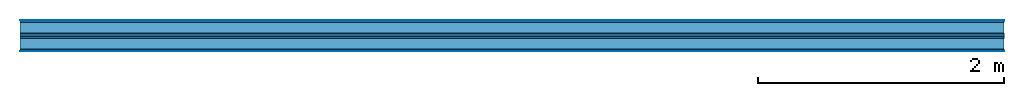
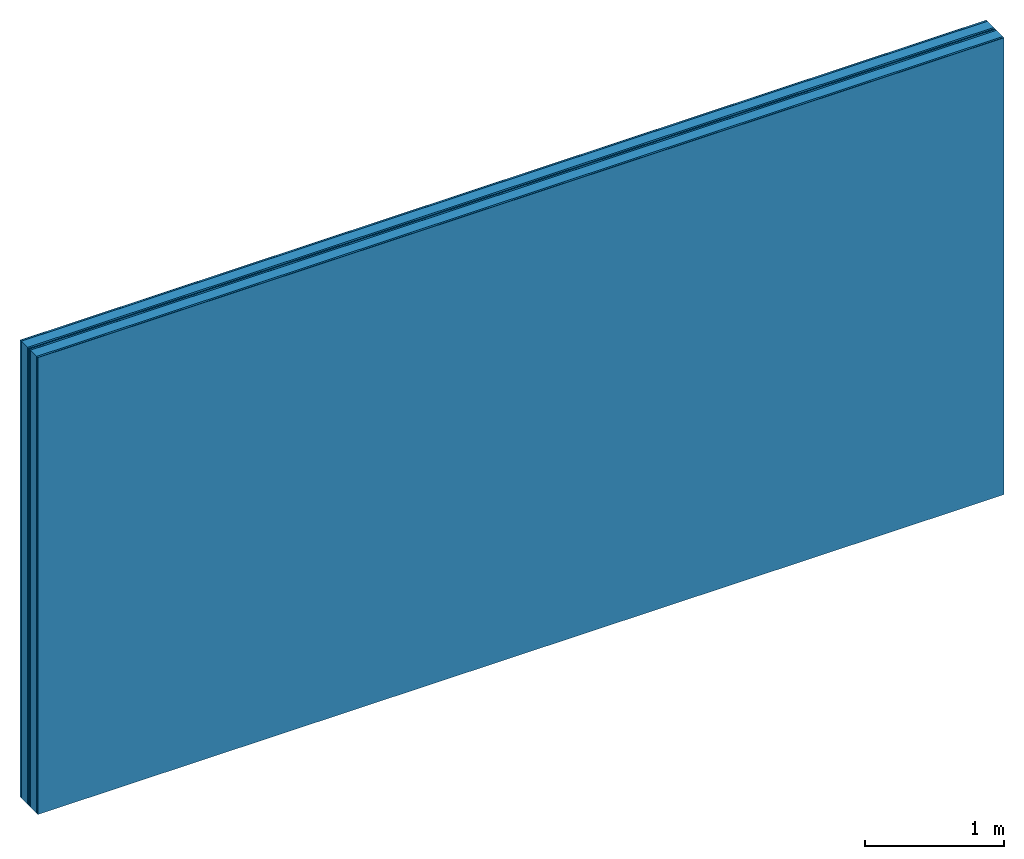
# One storey: 7 plates, 2 members, 1 element without a shape of its own.
"""IFC4 building model written with IfcOpenShell, lengths in metres."""

from ifc_helpers import new_model, si_unit, derived_unit, direction, frame, frame_2d, origin, origin_with_axes, place, context, project, spatial, rectangle, extrude, material, layer, layer_set, type_object, element, aggregate, save


model = new_model("IFC4")

# Units and contexts
plan_context = context("Plan", 3, precision=1e-05, world=origin(), true_north=direction((0.0, 1.0)))
model_context = context("Model", 3, precision=1e-05, world=origin(), true_north=direction((0.0, 1.0)))
ifc_project = project(units=[si_unit("LENGTHUNIT", "METRE"), derived_unit("SOUNDPRESSUREUNIT", [(si_unit("PRESSUREUNIT", "PASCAL", prefix="MICRO"), 0)]), si_unit("ENERGYUNIT", "JOULE", prefix="MEGA"), si_unit("MASSUNIT", "GRAM", prefix="KILO"), derived_unit("THERMALTRANSMITTANCEUNIT", [(si_unit("POWERUNIT", "WATT"), 1), (si_unit("AREAUNIT", "SQUARE_METRE"), -1), (si_unit("THERMODYNAMICTEMPERATUREUNIT", "KELVIN"), -1)]), derived_unit("AREADENSITYUNIT", [(si_unit("MASSUNIT", "GRAM", prefix="KILO"), 1), (si_unit("AREAUNIT", "SQUARE_METRE"), -1)]), derived_unit("USERDEFINED", [(si_unit("ENERGYUNIT", "JOULE", prefix="MEGA"), 1), (si_unit("AREAUNIT", "SQUARE_METRE"), -1)])], contexts=[plan_context, model_context])

# Site, building, storey
site = spatial("IfcSite", under=ifc_project)
building_placement = place(None, origin())
building = spatial("IfcBuilding", under=site, at=building_placement)
storey_placement = place(building_placement, origin())
storey = spatial("IfcBuildingStorey", under=building, at=storey_placement)

# Wall, members, plates
ifc_material_1 = material(Category="04.001")
ifc_layer_1 = layer(ifc_material_1, 0.003, Name="Surface")
ifc_material_2 = material(Name="DFH2IR Knauf Diamant hard- plasterboard", Category="03.007")
ifc_layer_2 = layer(ifc_material_2, 0.015, Name="room side 1st layer")
ifc_material_3 = material(Name="of the art")
ifc_layer_3 = layer(ifc_material_3, 0.0, Name="Bond")
ifc_layer_4 = layer(None, 0.09, Name="Support")
ifc_layer_5 = layer(ifc_material_3, 0.0, Name="Bond")
ifc_layer_6 = layer(ifc_material_2, 0.015, Name="outside 1st layer")
ifc_material_4 = material(Name="Air")
ifc_layer_7 = layer(ifc_material_4, 0.01, Name="Air gap")
ifc_layer_8 = layer(ifc_material_2, 0.015, Name="outside 1st layer")
ifc_layer_9 = layer(ifc_material_3, 0.0, Name="Bond")
ifc_layer_10 = layer(None, 0.09, Name="Support")
ifc_layer_11 = layer(ifc_material_3, 0.0, Name="Bond")
ifc_layer_12 = layer(ifc_material_2, 0.015, Name="room side 1st layer")
ifc_layer_13 = layer(ifc_material_1, 0.003, Name="Surface")
ifc_layer_set = layer_set([ifc_layer_1, ifc_layer_2, ifc_layer_3, ifc_layer_4, ifc_layer_5, ifc_layer_6, ifc_layer_7, ifc_layer_8, ifc_layer_9, ifc_layer_10, ifc_layer_11, ifc_layer_12, ifc_layer_13])
wall_type = type_object("IfcWallType", Name="B0298", PredefinedType="NOTDEFINED", material=ifc_layer_set)
wall_placement = place(None, frame((0.0, 0.0, 0.0), z_axis=(0.0, -1.0, 0.0), x_axis=(1.0, 0.0, 0.0)))
wall = element("IfcWall", 1, at=wall_placement, inside=storey, type_object=wall_type, material=ifc_layer_set, Name="Wall #1")
ifc_material_5 = material(Name="Solid timber panel")
member_1_placement = place(wall_placement, origin())
member_1 = element("IfcMember", 2, at=member_1_placement, material=ifc_material_5, Name="Support", context=plan_context, shape_type="SweptSolid", body=[
    extrude(rectangle(XDim=1.0, YDim=0.09, at=frame_2d((0.5, 0.045), x_axis=(1.0, 0.0))), frame((0.0, 4.0, 0.018), z_axis=(0.0, -1.0, 0.0), x_axis=(1.0, 0.0, 0.0)), (0.0, 0.0, 1.0), 4.0),
    extrude(rectangle(XDim=1.0, YDim=0.09, at=frame_2d((0.5, 0.045), x_axis=(1.0, 0.0))), frame((1.0, 4.0, 0.018), z_axis=(0.0, -1.0, 0.0), x_axis=(1.0, 0.0, 0.0)), (0.0, 0.0, 1.0), 4.0),
    extrude(rectangle(XDim=1.0, YDim=0.09, at=frame_2d((0.5, 0.045), x_axis=(1.0, 0.0))), frame((2.0, 4.0, 0.018), z_axis=(0.0, -1.0, 0.0), x_axis=(1.0, 0.0, 0.0)), (0.0, 0.0, 1.0), 4.0),
    extrude(rectangle(XDim=1.0, YDim=0.09, at=frame_2d((0.5, 0.045), x_axis=(1.0, 0.0))), frame((3.0, 4.0, 0.018), z_axis=(0.0, -1.0, 0.0), x_axis=(1.0, 0.0, 0.0)), (0.0, 0.0, 1.0), 4.0),
    extrude(rectangle(XDim=1.0, YDim=0.09, at=frame_2d((0.5, 0.045), x_axis=(1.0, 0.0))), frame((4.0, 4.0, 0.018), z_axis=(0.0, -1.0, 0.0), x_axis=(1.0, 0.0, 0.0)), (0.0, 0.0, 1.0), 4.0),
    extrude(rectangle(XDim=1.0, YDim=0.09, at=frame_2d((0.5, 0.045), x_axis=(1.0, 0.0))), frame((5.0, 4.0, 0.018), z_axis=(0.0, -1.0, 0.0), x_axis=(1.0, 0.0, 0.0)), (0.0, 0.0, 1.0), 4.0),
    extrude(rectangle(XDim=1.0, YDim=0.09, at=frame_2d((0.5, 0.045), x_axis=(1.0, 0.0))), frame((6.0, 4.0, 0.018), z_axis=(0.0, -1.0, 0.0), x_axis=(1.0, 0.0, 0.0)), (0.0, 0.0, 1.0), 4.0),
    extrude(rectangle(XDim=1.0, YDim=0.09, at=frame_2d((0.5, 0.045), x_axis=(1.0, 0.0))), frame((7.0, 4.0, 0.018), z_axis=(0.0, -1.0, 0.0), x_axis=(1.0, 0.0, 0.0)), (0.0, 0.0, 1.0), 4.0),
])
member_2_placement = place(wall_placement, origin())
member_2 = element("IfcMember", 3, at=member_2_placement, material=ifc_material_5, Name="Support", context=plan_context, shape_type="SweptSolid", body=[
    extrude(rectangle(XDim=1.0, YDim=0.09, at=frame_2d((0.5, 0.045), x_axis=(1.0, 0.0))), frame((0.0, 4.0, 0.148), z_axis=(0.0, -1.0, 0.0), x_axis=(1.0, 0.0, 0.0)), (0.0, 0.0, 1.0), 4.0),
    extrude(rectangle(XDim=1.0, YDim=0.09, at=frame_2d((0.5, 0.045), x_axis=(1.0, 0.0))), frame((1.0, 4.0, 0.148), z_axis=(0.0, -1.0, 0.0), x_axis=(1.0, 0.0, 0.0)), (0.0, 0.0, 1.0), 4.0),
    extrude(rectangle(XDim=1.0, YDim=0.09, at=frame_2d((0.5, 0.045), x_axis=(1.0, 0.0))), frame((2.0, 4.0, 0.148), z_axis=(0.0, -1.0, 0.0), x_axis=(1.0, 0.0, 0.0)), (0.0, 0.0, 1.0), 4.0),
    extrude(rectangle(XDim=1.0, YDim=0.09, at=frame_2d((0.5, 0.045), x_axis=(1.0, 0.0))), frame((3.0, 4.0, 0.148), z_axis=(0.0, -1.0, 0.0), x_axis=(1.0, 0.0, 0.0)), (0.0, 0.0, 1.0), 4.0),
    extrude(rectangle(XDim=1.0, YDim=0.09, at=frame_2d((0.5, 0.045), x_axis=(1.0, 0.0))), frame((4.0, 4.0, 0.148), z_axis=(0.0, -1.0, 0.0), x_axis=(1.0, 0.0, 0.0)), (0.0, 0.0, 1.0), 4.0),
    extrude(rectangle(XDim=1.0, YDim=0.09, at=frame_2d((0.5, 0.045), x_axis=(1.0, 0.0))), frame((5.0, 4.0, 0.148), z_axis=(0.0, -1.0, 0.0), x_axis=(1.0, 0.0, 0.0)), (0.0, 0.0, 1.0), 4.0),
    extrude(rectangle(XDim=1.0, YDim=0.09, at=frame_2d((0.5, 0.045), x_axis=(1.0, 0.0))), frame((6.0, 4.0, 0.148), z_axis=(0.0, -1.0, 0.0), x_axis=(1.0, 0.0, 0.0)), (0.0, 0.0, 1.0), 4.0),
    extrude(rectangle(XDim=1.0, YDim=0.09, at=frame_2d((0.5, 0.045), x_axis=(1.0, 0.0))), frame((7.0, 4.0, 0.148), z_axis=(0.0, -1.0, 0.0), x_axis=(1.0, 0.0, 0.0)), (0.0, 0.0, 1.0), 4.0),
])
plate_1_placement = place(wall_placement, origin())
plate_1 = element("IfcPlate", 4, at=plate_1_placement, material=ifc_material_1, Name="Surface", context=plan_context, shape_type="SweptSolid", body=[
    extrude(rectangle(XDim=8.0, YDim=4.0, at=frame_2d((4.0, 2.0), x_axis=(1.0, 0.0))), origin_with_axes(), (0.0, 0.0, 1.0), 0.003),
])
plate_2_placement = place(wall_placement, origin())
plate_2 = element("IfcPlate", 5, at=plate_2_placement, material=ifc_material_2, Name="room side 1st layer", context=plan_context, shape_type="SweptSolid", body=[
    extrude(rectangle(XDim=8.0, YDim=4.0, at=frame_2d((4.0, 2.0), x_axis=(1.0, 0.0))), frame((0.0, 0.0, 0.003), z_axis=(0.0, 0.0, 1.0), x_axis=(1.0, 0.0, 0.0)), (0.0, 0.0, 1.0), 0.015),
])
plate_3_placement = place(wall_placement, origin())
plate_3 = element("IfcPlate", 6, at=plate_3_placement, material=ifc_material_2, Name="outside 1st layer", context=plan_context, shape_type="SweptSolid", body=[
    extrude(rectangle(XDim=8.0, YDim=4.0, at=frame_2d((4.0, 2.0), x_axis=(1.0, 0.0))), frame((0.0, 0.0, 0.108), z_axis=(0.0, 0.0, 1.0), x_axis=(1.0, 0.0, 0.0)), (0.0, 0.0, 1.0), 0.015),
])
plate_4_placement = place(wall_placement, origin())
plate_4 = element("IfcPlate", 7, at=plate_4_placement, material=ifc_material_4, Name="Air gap", context=plan_context, shape_type="SweptSolid", body=[
    extrude(rectangle(XDim=8.0, YDim=4.0, at=frame_2d((4.0, 2.0), x_axis=(1.0, 0.0))), frame((0.0, 0.0, 0.123), z_axis=(0.0, 0.0, 1.0), x_axis=(1.0, 0.0, 0.0)), (0.0, 0.0, 1.0), 0.01),
])
plate_5_placement = place(wall_placement, origin())
plate_5 = element("IfcPlate", 8, at=plate_5_placement, material=ifc_material_2, Name="outside 1st layer", context=plan_context, shape_type="SweptSolid", body=[
    extrude(rectangle(XDim=8.0, YDim=4.0, at=frame_2d((4.0, 2.0), x_axis=(1.0, 0.0))), frame((0.0, 0.0, 0.133), z_axis=(0.0, 0.0, 1.0), x_axis=(1.0, 0.0, 0.0)), (0.0, 0.0, 1.0), 0.015),
])
plate_6_placement = place(wall_placement, origin())
plate_6 = element("IfcPlate", 9, at=plate_6_placement, material=ifc_material_2, Name="room side 1st layer", context=plan_context, shape_type="SweptSolid", body=[
    extrude(rectangle(XDim=8.0, YDim=4.0, at=frame_2d((4.0, 2.0), x_axis=(1.0, 0.0))), frame((0.0, 0.0, 0.238), z_axis=(0.0, 0.0, 1.0), x_axis=(1.0, 0.0, 0.0)), (0.0, 0.0, 1.0), 0.015),
])
plate_7_placement = place(wall_placement, origin())
plate_7 = element("IfcPlate", 10, at=plate_7_placement, material=ifc_material_1, Name="Surface", context=plan_context, shape_type="SweptSolid", body=[
    extrude(rectangle(XDim=8.0, YDim=4.0, at=frame_2d((4.0, 2.0), x_axis=(1.0, 0.0))), frame((0.0, 0.0, 0.253), z_axis=(0.0, 0.0, 1.0), x_axis=(1.0, 0.0, 0.0)), (0.0, 0.0, 1.0), 0.003),
])
aggregate(wall, [plate_1, plate_2, member_1, plate_3, plate_4, plate_5, member_2, plate_6, plate_7])

save(model, "model.ifc")
